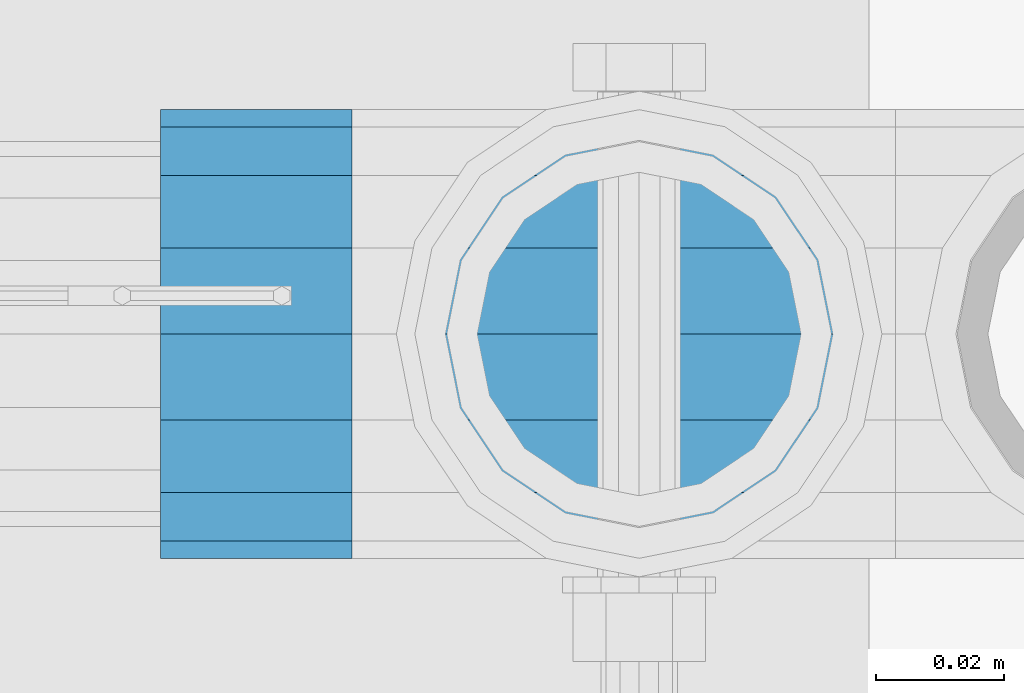
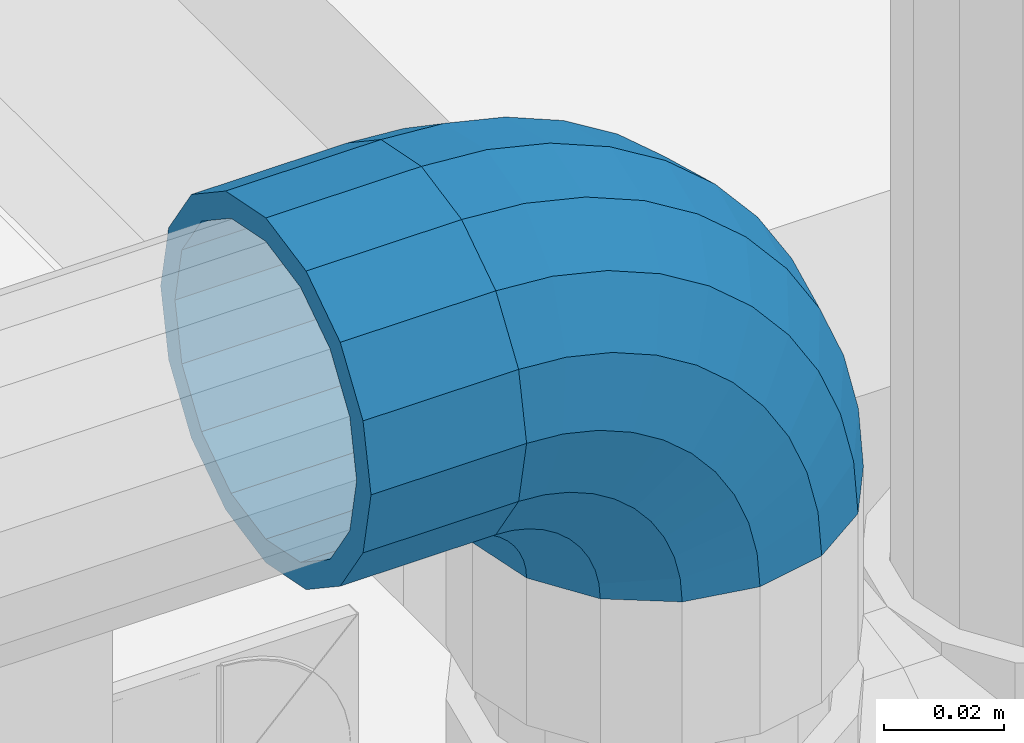
# One storey, part 141 of 208: 1 beam, 1 member.
"""IFC2X3 building model written with IfcOpenShell, lengths in millimetres."""

from ifc_helpers import new_model, si_unit, frame, origin_with_axes, place, context, subcontext, project, spatial, faceted_brep, material, type_object, element, save


model = new_model("IFC2X3")

# Units and contexts
model_context = context("Model", 3, precision=1e-05, world=origin_with_axes())
body_context = subcontext(model_context, "Body", "Model", "MODEL_VIEW")
ifc_project = project(units=[si_unit("LENGTHUNIT", "METRE", prefix="MILLI"), si_unit("AREAUNIT", "SQUARE_METRE"), si_unit("VOLUMEUNIT", "CUBIC_METRE"), si_unit("MASSUNIT", "GRAM", prefix="KILO"), si_unit("TIMEUNIT", "SECOND"), si_unit("PLANEANGLEUNIT", "RADIAN"), si_unit("SOLIDANGLEUNIT", "STERADIAN"), si_unit("THERMODYNAMICTEMPERATUREUNIT", "DEGREE_CELSIUS"), si_unit("LUMINOUSINTENSITYUNIT", "LUMEN")], contexts=[model_context])

# Site, building, storey
site_placement = place(None, origin_with_axes())
site = spatial("IfcSite", under=ifc_project, at=site_placement, CompositionType="ELEMENT")
building_placement = place(site_placement, origin_with_axes())
building = spatial("IfcBuilding", under=site, at=building_placement, Name="Standard", CompositionType="ELEMENT")
storey_placement = place(building_placement, origin_with_axes())
storey = spatial("IfcBuildingStorey", under=building, at=storey_placement, Name="Undefined", CompositionType="ELEMENT", Elevation=0.0)

# Beam
ifc_material = material(Name="Misc_Undefined")
beam_type = type_object("IfcBeamType", PredefinedType="NOTDEFINED")
beam_placement = place(storey_placement, frame((-26274.0, 4664.5, 969.85), z_axis=(0.0, 0.0, 1.0), x_axis=(-1.0, 0.0, 0.0)))
element("IfcBeam", 1, at=beam_placement, inside=storey, type_object=beam_type, material=ifc_material, context=body_context, shape_type="Brep", body=[
    faceted_brep([(0.0, -30.3500000000004, 0.0), (0.0, -28.0397438117179, 11.6144421722784), (30.0, -28.0397438117179, 11.6144421722805), (30.0, -30.3500000000004, 0.0), (0.0, -21.4606908090118, 21.4606908090136), (30.0, -21.4606908090118, 21.4606908090117), (0.0, -11.6144421722802, 28.0397438117143), (30.0, -11.6144421722802, 28.0397438117175), (0.0, 0.0, 30.3499999999985), (30.0, 0.0, 30.35), (0.0, 11.6144421722802, 28.0397438117143), (30.0, 11.6144421722802, 28.0397438117175), (0.0, 21.4606908090118, 21.4606908090136), (30.0, 21.4606908090118, 21.4606908090117), (0.0, 28.0397438117179, 11.6144421722784), (30.0, 28.0397438117179, 11.6144421722805), (0.0, 30.3500000000004, 0.0), (30.0, 30.3500000000004, 0.0), (0.0, 28.0397438117179, -11.6144421722784), (30.0, 28.0397438117179, -11.6144421722805), (0.0, 21.4606908090118, -21.4606908090136), (30.0, 21.4606908090118, -21.4606908090117), (0.0, 11.6144421722802, -28.0397438117143), (30.0, 11.6144421722802, -28.0397438117175), (0.0, 0.0, -30.3499999999985), (30.0, 0.0, -30.35), (0.0, -11.6144421722802, -28.0397438117143), (30.0, -11.6144421722802, -28.0397438117175), (0.0, -21.4606908090118, -21.4606908090136), (30.0, -21.4606908090118, -21.4606908090117), (0.0, -28.0397438117179, -11.6144421722784), (30.0, -28.0397438117179, -11.6144421722805), (0.0, -35.1499999999996, 0.0), (0.0, -32.4743655677721, -13.4513226476338), (30.0, -32.4743655677721, -13.4513226476329), (30.0, -35.1499999999996, 0.0), (0.0, -24.8548033587067, -24.8548033587067), (30.0, -24.8548033587067, -24.8548033587072), (0.0, -13.4513226476329, -32.4743655677739), (30.0, -13.4513226476329, -32.4743655677717), (0.0, 0.0, -35.1499999999996), (30.0, 0.0, -35.15), (0.0, 13.4513226476329, -32.4743655677739), (30.0, 13.4513226476329, -32.4743655677717), (0.0, 24.8548033587067, -24.8548033587067), (30.0, 24.8548033587067, -24.8548033587072), (0.0, 32.4743655677721, -13.4513226476338), (30.0, 32.4743655677721, -13.4513226476329), (0.0, 35.1499999999996, 0.0), (30.0, 35.1499999999996, 0.0), (0.0, 32.4743655677721, 13.4513226476338), (30.0, 32.4743655677721, 13.4513226476329), (0.0, 24.8548033587067, 24.8548033587067), (30.0, 24.8548033587067, 24.8548033587072), (0.0, 13.4513226476329, 32.4743655677739), (30.0, 13.4513226476329, 32.4743655677717), (0.0, 0.0, 35.1499999999996), (30.0, 0.0, 35.15), (0.0, -13.4513226476329, 32.4743655677739), (30.0, -13.4513226476329, 32.4743655677717), (0.0, -24.8548033587067, 24.8548033587067), (30.0, -24.8548033587067, 24.8548033587072), (0.0, -32.4743655677721, 13.4513226476338), (30.0, -32.4743655677721, 13.4513226476329)], [[[0, 1, 2, 3]], [[1, 4, 5, 2]], [[4, 6, 7, 5]], [[6, 8, 9, 7]], [[8, 10, 11, 9]], [[10, 12, 13, 11]], [[12, 14, 15, 13]], [[14, 16, 17, 15]], [[16, 18, 19, 17]], [[18, 20, 21, 19]], [[20, 22, 23, 21]], [[22, 24, 25, 23]], [[24, 26, 27, 25]], [[26, 28, 29, 27]], [[28, 30, 31, 29]], [[30, 0, 3, 31]], [[32, 33, 34, 35]], [[33, 36, 37, 34]], [[36, 38, 39, 37]], [[38, 40, 41, 39]], [[40, 42, 43, 41]], [[42, 44, 45, 43]], [[44, 46, 47, 45]], [[46, 48, 49, 47]], [[48, 50, 51, 49]], [[50, 52, 53, 51]], [[52, 54, 55, 53]], [[54, 56, 57, 55]], [[56, 58, 59, 57]], [[58, 60, 61, 59]], [[60, 62, 63, 61]], [[62, 32, 35, 63]], [[37, 39, 41, 43, 45, 47, 49, 51, 53, 55, 57, 59, 61, 63, 35, 34], [5, 7, 9, 11, 13, 15, 17, 19, 21, 23, 25, 27, 29, 31, 3, 2]], [[62, 60, 58, 56, 54, 52, 50, 48, 46, 44, 42, 40, 38, 36, 33, 32], [30, 28, 26, 24, 22, 20, 18, 16, 14, 12, 10, 8, 6, 4, 1, 0]]]),
])

# Member
member_type = type_object("IfcMemberType", PredefinedType="NOTDEFINED")
member_placement = place(storey_placement, frame((-26229.0, 4664.5, 924.85), z_axis=(0.707106781186539, -1.49999999888231e-07, 0.70710678118654), x_axis=(-0.707106781186548, 0.0, 0.707106781186548)))
element("IfcMember", 2, at=member_placement, inside=storey, type_object=member_type, material=ifc_material, context=body_context, shape_type="Brep", body=[
    faceted_brep([(0.0, -35.1499999999996, 0.0), (9.51152146007371, -32.4743655677721, -9.51152146006643), (13.2759578763435, -32.4743655677721, -6.29638902527222), (5.3694688002397, -35.1499999999996, 4.58595959348168), (17.5750000000044, -24.8548033587067, -17.5749999999971), (19.9787556631163, -24.8548033587067, -15.5219987155615), (22.9628441077075, -13.4513226476329, -22.9628441076966), (24.4574219585302, -13.4513226476329, -21.6863540323902), (24.854803358714, 0.0, -24.8548033587031), (26.0301204183197, 0.0, -23.8509877588003), (22.9628441077075, 13.4513226476329, -22.9628441076966), (24.4574219585302, 13.4513226476329, -21.6863540323902), (17.5750000000044, 24.8548033587067, -17.5749999999971), (19.9787556631163, 24.8548033587067, -15.5219987155615), (9.51152146007371, 32.4743655677721, -9.51152146006643), (13.2759578763435, 32.4743655677721, -6.29638902527222), (0.0, 35.1499999999996, 0.0), (5.3694688002397, 35.1499999999996, 4.58595959348168), (-9.51152146006643, 32.4743655677721, 9.51152146007371), (-2.53702027587133, 32.4743655677721, 15.4683082122356), (-17.5749999999935, 24.8548033587067, 17.5750000000044), (-9.23981806264055, 24.8548033587067, 24.6939179025248), (-22.9628441076966, 13.4513226476329, 22.9628441077039), (-13.7184843580508, 13.4513226476329, 30.8582732193536), (-24.8548033587031, 0.0, 24.854803358714), (-15.2911828178439, 0.0, 33.02290694576), (-22.9628441076966, -13.4513226476329, 22.9628441077039), (-13.7184843580508, -13.4513226476329, 30.8582732193536), (-17.5749999999935, -24.8548033587067, 17.5750000000044), (-9.23981806264055, -24.8548033587067, 24.6939179025248), (-9.51152146006643, -32.4743655677721, 9.51152146007371), (-2.53702027587133, -32.4743655677721, 15.4683082122356), (0.0, -30.3500000000004, 0.0), (-8.21265081971433, -28.0397438117179, 8.21265081972524), (-1.45732902223244, -28.0397438117179, 13.9822406910389), (5.3694688002397, -30.3500000000004, 4.58595959348168), (-15.1749999999956, -21.4606908090118, 15.1750000000029), (-7.24480876130838, -21.4606908090118, 21.9480231689995), (-19.8270929919963, -11.6144421722802, 19.8270929920036), (-11.1118790903529, -11.6144421722802, 27.2705888550809), (-21.4606908090063, 0.0, 21.4606908090136), (-12.46981360684, 0.0, 29.139625372758), (-19.8270929919963, 11.6144421722802, 19.8270929920036), (-11.1118790903529, 11.6144421722802, 27.2705888550809), (-15.1749999999956, 21.4606908090118, 15.1750000000029), (-7.24480876130838, 21.4606908090118, 21.9480231689995), (-8.21265081971433, 28.0397438117179, 8.21265081972524), (-1.45732902223244, 28.0397438117179, 13.9822406910389), (0.0, 30.3500000000004, 0.0), (5.3694688002397, 30.3500000000004, 4.58595959348168), (8.21265081972524, 28.0397438117179, -8.21265081971433), (12.1962666227082, 28.0397438117179, -4.81032150407918), (15.1750000000029, 21.4606908090118, -15.1749999999956), (17.9837463617841, 21.4606908090118, -12.7761039820325), (19.8270929920036, 11.6144421722802, -19.8270929919963), (21.850816690825, 11.6144421722802, -18.0986696681175), (21.4606908090136, 0.0, -21.4606908090063), (23.2087512073158, 0.0, -19.9677061857983), (19.8270929920036, -11.6144421722802, -19.8270929919963), (21.850816690825, -11.6144421722802, -18.0986696681175), (15.1750000000029, -21.4606908090118, -15.1749999999956), (17.9837463617841, -21.4606908090118, -12.7761039820325), (8.21265081972524, -28.0397438117179, -8.21265081971433), (12.1962666227082, -28.0397438117179, -4.81032150407918), (17.4970053560755, -32.4743655677721, -3.70972780291777), (11.3902326651187, -35.1499999999996, 8.27548843508339), (22.6740772628655, -24.8548033587067, -13.870303514941), (26.1332861179544, -13.4513226476329, -20.6593831546779), (27.3479987309656, 0.0, -23.0433908901359), (26.1332861179544, 13.4513226476329, -20.6593831546779), (22.6740772628655, 24.8548033587067, -13.870303514941), (17.4970053560755, 32.4743655677721, -3.70972780291777), (11.3902326651187, 35.1499999999996, 8.27548843508339), (5.28345997416181, 32.4743655677721, 20.2607046730918), (0.106388067368243, 24.8548033587067, 30.4212803851115), (-3.3528207877207, 13.4513226476329, 37.2103600248483), (-4.56753340072828, 0.0, 39.59436776031), (-3.3528207877207, -13.4513226476329, 37.2103600248483), (0.106388067368243, -24.8548033587067, 30.4212803851115), (5.28345997416181, -32.4743655677721, 20.2607046730918), (6.11738625912767, -28.0397438117179, 18.6240321853948), (11.3902326651187, -30.3500000000004, 8.27548843508339), (1.64728291998108, -21.4606908090118, 27.3971039595053), (-1.33954464053022, -11.6144421722802, 33.2590831078996), (-2.38837900197541, 0.0, 35.3175364441995), (-1.33954464053022, 11.6144421722802, 33.2590831078996), (1.64728291998108, 21.4606908090118, 27.3971039595053), (6.11738625912767, 28.0397438117179, 18.6240321853948), (11.3902326651187, 30.3500000000004, 8.27548843508339), (16.663079071106, 28.0397438117179, -2.07305531522434), (21.1331824102563, 21.4606908090118, -10.8461270893349), (24.1200099707712, 11.6144421722802, -16.7081062377256), (25.1688443322128, 0.0, -18.7665595740327), (24.1200099707712, -11.6144421722802, -16.7081062377256), (21.1331824102563, -21.4606908090118, -10.8461270893349), (16.663079071106, -28.0397438117179, -2.07305531522434), (22.0707277014626, -32.4743655677721, -1.81522997692809), (17.9140404065256, -35.1499999999996, 10.9777380798914), (25.5945970362154, -24.8548033587067, -12.6605846156417), (27.9491712485142, -13.4513226476329, -19.9072189058897), (28.7759877588032, 0.0, -22.4518984678834), (27.9491712485142, 13.4513226476329, -19.9072189058897), (25.5945970362154, 24.8548033587067, -12.6605846156417), (22.0707277014626, 32.4743655677721, -1.81522997692809), (17.9140404065256, 35.1499999999996, 10.9777380798914), (13.7573531115886, 32.4743655677721, 23.7707061367109), (10.2334837768358, 24.8548033587067, 34.6160607754246), (7.87890956454066, 13.4513226476329, 41.8626950656726), (7.05209305424796, 0.0, 44.4073746276663), (7.87890956454066, -13.4513226476329, 41.8626950656726), (10.2334837768358, -24.8548033587067, 34.6160607754246), (13.7573531115886, -32.4743655677721, 23.7707061367109), (14.3249803951076, -28.0397438117179, 22.023728990971), (17.9140404065256, -30.3500000000004, 10.9777380798914), (11.2823222355146, -21.4606908090118, 31.3880679180002), (9.2492830507872, -11.6144421722802, 37.6451191472734), (8.53537462724489, 0.0, 39.8423033494473), (9.2492830507872, 11.6144421722802, 37.6451191472734), (11.2823222355146, 21.4606908090118, 31.3880679180002), (14.3249803951076, 28.0397438117179, 22.023728990971), (17.9140404065256, 30.3500000000004, 10.9777380798914), (21.5031004179436, 28.0397438117179, -0.0682528311917849), (24.5457585775366, 21.4606908090118, -9.43259175821368), (26.5787977622676, 11.6144421722802, -15.6896429874905), (27.2927061858063, 0.0, -17.8868271896645), (26.5787977622676, -11.6144421722802, -15.6896429874905), (24.5457585775366, -21.4606908090118, -9.43259175821368), (21.5031004179436, -28.0397438117179, -0.0682528311917849), (26.8845046890528, -32.4743655677721, -0.659544371261291), (24.7802542265854, -35.1499999999996, 12.6261701733893), (28.6684020936882, -24.8548033587067, -11.9226293117899), (29.860364231703, -13.4513226476329, -19.4483820661189), (30.2789256727519, 0.0, -22.0910749985305), (29.860364231703, 13.4513226476329, -19.4483820661189), (28.6684020936882, 24.8548033587067, -11.9226293117899), (26.8845046890528, 32.4743655677721, -0.659544371261291), (24.7802542265854, 35.1499999999996, 12.6261701733893), (22.6760037641179, 32.4743655677721, 25.9118847180434), (20.8921063594898, 24.8548033587067, 37.1749696585721), (19.7001442214714, 13.4513226476329, 44.7007224129011), (19.2815827804225, 0.0, 47.343415345309), (19.7001442214714, -13.4513226476329, 44.7007224129011), (20.8921063594898, -24.8548033587067, 37.1749696585721), (22.6760037641179, -32.4743655677721, 25.9118847180434), (22.9633551786246, -28.0397438117179, 24.0976192894668), (24.7802542265854, -30.3500000000004, 12.6261701733893), (21.4230625404853, -21.4606908090118, 33.8226442665691), (20.3938719035395, -11.6144421722802, 40.3206982094998), (20.0324682126193, 0.0, 42.6025113104552), (20.3938719035395, 11.6144421722802, 40.3206982094998), (21.4230625404853, 21.4606908090118, 33.8226442665691), (22.9633551786246, 28.0397438117179, 24.0976192894668), (24.7802542265854, 30.3500000000004, 12.6261701733893), (26.5971532745498, 28.0397438117179, 1.15472105731169), (28.1374459126891, 21.4606908090118, -8.5703039197906), (29.1666365496385, 11.6144421722802, -15.0683578627177), (29.5280402405588, 0.0, -17.350170963673), (29.1666365496385, -11.6144421722802, -15.0683578627177), (28.1374459126891, -21.4606908090118, -8.5703039197906), (26.5971532745498, -28.0397438117179, 1.15472105731169), (31.8198051533982, -32.4743655677721, -0.271127801024704), (31.8198051533982, -35.1499999999996, 13.1801948466091), (31.8198051533982, -24.8548033587067, -11.6746085120976), (31.8198051533982, -13.4513226476329, -19.2941707211648), (31.8198051533982, 0.0, -21.9698051533924), (31.8198051533982, 13.4513226476329, -19.2941707211648), (31.8198051533982, 24.8548033587067, -11.6746085120976), (31.8198051533982, 32.4743655677721, -0.271127801024704), (31.8198051533982, 35.1499999999996, 13.1801948466091), (31.8198051533982, 32.4743655677721, 26.6315174942429), (31.8198051533982, 24.8548033587067, 38.0349982053158), (31.8198051533946, 13.4513226476329, 45.654560414383), (31.8198051534018, 0.0, 48.3301948466105), (31.8198051533946, -13.4513226476329, 45.654560414383), (31.8198051533982, -24.8548033587067, 38.0349982053158), (31.8198051533982, -32.4743655677721, 26.6315174942429), (31.8198051533982, -28.0397438117179, 24.7946370188874), (31.8198051533982, -30.3500000000004, 13.1801948466091), (31.8198051533982, -21.4606908090118, 34.6408856556227), (31.8198051533982, -11.6144421722802, 41.219938658327), (31.8198051533982, 0.0, 43.5301948466113), (31.8198051533982, 11.6144421722802, 41.219938658327), (31.8198051533982, 21.4606908090118, 34.6408856556227), (31.8198051533982, 28.0397438117179, 24.7946370188874), (31.8198051533982, 30.3500000000004, 13.1801948466091), (31.8198051533946, 28.0397438117179, 1.56575267433072), (31.8198051533982, 21.4606908090118, -8.28049596240453), (31.8198051533982, 11.6144421722802, -14.8595489651088), (31.8198051533982, 0.0, -17.1698051533895), (31.8198051533982, -11.6144421722802, -14.8595489651088), (31.8198051533982, -21.4606908090118, -8.28049596240453), (31.8198051533946, -28.0397438117179, 1.56575267433072), (36.7551056177435, -32.4743655677721, -0.659544371261291), (38.859356080211, -35.1499999999996, 12.6261701733929), (34.9712082131082, -24.8548033587067, -11.9226293117899), (33.7792460750898, -13.4513226476329, -19.4483820661189), (33.3606846340444, 0.0, -22.0910749985269), (33.7792460750898, 13.4513226476329, -19.4483820661189), (34.9712082131082, 24.8548033587067, -11.9226293117899), (36.7551056177435, 32.4743655677721, -0.659544371261291), (38.859356080211, 35.1499999999996, 12.6261701733929), (40.9636065426712, 32.4743655677721, 25.9118847180434), (42.7475039473065, 24.8548033587067, 37.1749696585684), (43.939466085325, 13.4513226476329, 44.7007224129047), (44.3580275263703, 0.0, 47.343415345309), (43.939466085325, -13.4513226476329, 44.7007224129047), (42.7475039473065, -24.8548033587067, 37.1749696585684), (40.9636065426712, -32.4743655677721, 25.9118847180434), (40.6762551281718, -28.0397438117179, 24.0976192894668), (38.859356080211, -30.3500000000004, 12.6261701733929), (42.2165477663111, -21.4606908090118, 33.8226442665691), (43.2457384032568, -11.6144421722802, 40.3206982094998), (43.6071420941771, 0.0, 42.6025113104515), (43.2457384032568, 11.6144421722802, 40.3206982094998), (42.2165477663111, 21.4606908090118, 33.8226442665691), (40.6762551281718, 28.0397438117179, 24.0976192894668), (38.859356080211, 30.3500000000004, 12.6261701733929), (37.0424570322466, 28.0397438117179, 1.15472105731169), (35.5021643941072, 21.4606908090118, -8.5703039197906), (34.4729737571579, 11.6144421722802, -15.0683578627177), (34.1115700662376, 0.0, -17.350170963673), (34.4729737571579, -11.6144421722802, -15.0683578627177), (35.5021643941072, -21.4606908090118, -8.5703039197906), (37.0424570322466, -28.0397438117179, 1.15472105731169), (41.5688826053338, -32.4743655677721, -1.81522997692809), (45.7255699002708, -35.1499999999996, 10.9777380798914), (38.045013270581, -24.8548033587067, -12.6605846156417), (35.6904390582822, -13.4513226476329, -19.9072189058897), (34.8636225479895, 0.0, -22.4518984678834), (35.6904390582822, 13.4513226476329, -19.9072189058897), (38.045013270581, 24.8548033587067, -12.6605846156417), (41.5688826053338, 32.4743655677721, -1.81522997692809), (45.7255699002708, 35.1499999999996, 10.9777380798914), (49.8822571952114, 32.4743655677721, 23.7707061367109), (53.4061265299606, 24.8548033587067, 34.6160607754246), (55.7607007422557, 13.4513226476329, 41.8626950656726), (56.5875172525484, 0.0, 44.4073746276699), (55.7607007422557, -13.4513226476329, 41.8626950656726), (53.4061265299606, -24.8548033587067, 34.6160607754246), (49.8822571952114, -32.4743655677721, 23.7707061367109), (49.3146299116925, -28.0397438117179, 22.0237289909746), (45.7255699002708, -30.3500000000004, 10.9777380798914), (52.3572880712818, -21.4606908090118, 31.3880679179965), (54.3903272560092, -11.6144421722802, 37.6451191472697), (55.1042356795515, 0.0, 39.8423033494473), (54.3903272560092, 11.6144421722802, 37.6451191472697), (52.3572880712818, 21.4606908090118, 31.3880679179965), (49.3146299116925, 28.0397438117179, 22.0237289909746), (45.7255699002708, 30.3500000000004, 10.9777380798914), (42.1365098888527, 28.0397438117179, -0.0682528311917849), (39.0938517292598, 21.4606908090118, -9.43259175821368), (37.0608125445287, 11.6144421722802, -15.6896429874905), (36.3469041209937, 0.0, -17.8868271896645), (37.0608125445287, -11.6144421722802, -15.6896429874905), (39.0938517292598, -21.4606908090118, -9.43259175821368), (42.1365098888527, -28.0397438117179, -0.0682528311917849), (46.1426049507245, -32.4743655677721, -3.70972780291777), (52.2493776416777, -35.1499999999996, 8.27548843508339), (40.9655330439309, -24.8548033587067, -13.870303514941), (37.506324188842, -13.4513226476329, -20.6593831546743), (36.2916115758308, 0.0, -23.0433908901359), (37.506324188842, 13.4513226476329, -20.6593831546743), (40.9655330439309, 24.8548033587067, -13.870303514941), (46.1426049507245, 32.4743655677721, -3.70972780291777), (52.2493776416777, 35.1499999999996, 8.27548843508339), (58.3561503326309, 32.4743655677721, 20.2607046730918), (63.5332222394245, 24.8548033587067, 30.4212803851151), (66.9924310945171, 13.4513226476329, 37.2103600248483), (68.207143707521, 0.0, 39.5943677603063), (66.9924310945171, -13.4513226476329, 37.2103600248483), (63.5332222394245, -24.8548033587067, 30.4212803851151), (58.3561503326309, -32.4743655677721, 20.2607046730918), (57.5222240476687, -28.0397438117179, 18.6240321853984), (52.2493776416777, -30.3500000000004, 8.27548843508339), (61.9923273868153, -21.4606908090118, 27.3971039595053), (64.9791549473266, -11.6144421722802, 33.259083107896), (66.0279893087718, 0.0, 35.3175364442068), (64.9791549473266, 11.6144421722802, 33.259083107896), (61.9923273868153, 21.4606908090118, 27.3971039595053), (57.5222240476687, 28.0397438117179, 18.6240321853984), (52.2493776416777, 30.3500000000004, 8.27548843508339), (46.9765312356867, 28.0397438117179, -2.0730553152207), (42.5064278965401, 21.4606908090118, -10.8461270893349), (39.5196003360288, 11.6144421722802, -16.7081062377256), (38.4707659745836, 0.0, -18.7665595740327), (39.5196003360288, -11.6144421722802, -16.7081062377256), (42.5064278965401, -21.4606908090118, -10.8461270893349), (46.9765312356867, -28.0397438117179, -2.0730553152207), (50.3636524304529, -32.4743655677721, -6.29638902527222), (58.2701415065603, -35.1499999999996, 4.58595959348168), (43.6608546436801, -24.8548033587067, -15.5219987155615), (39.1821883482698, -13.4513226476329, -21.6863540323902), (37.6094898884767, 0.0, -23.8509877587967), (39.1821883482698, 13.4513226476329, -21.6863540323902), (43.6608546436801, 24.8548033587067, -15.5219987155615), (50.3636524304529, 32.4743655677721, -6.29638902527222), (58.2701415065603, 35.1499999999996, 4.58595959348168), (66.1766305826677, 32.4743655677721, 15.4683082122392), (72.8794283694369, 24.8548033587067, 24.6939179025212), (77.3580946648508, 13.4513226476329, 30.8582732193536), (78.9307931246403, 0.0, 33.02290694576), (77.3580946648508, -13.4513226476329, 30.8582732193536), (72.8794283694369, -24.8548033587067, 24.6939179025212), (66.1766305826677, -32.4743655677721, 15.4683082122392), (65.0969393290288, -28.0397438117179, 13.9822406910425), (58.2701415065603, -30.3500000000004, 4.58595959348168), (70.8844190681048, -21.4606908090118, 21.9480231689995), (74.7514893971456, -11.6144421722802, 27.2705888550845), (76.1094239136364, 0.0, 29.1396253727617), (74.7514893971456, 11.6144421722802, 27.2705888550845), (70.8844190681048, 21.4606908090118, 21.9480231689995), (65.0969393290288, 28.0397438117179, 13.9822406910425), (58.2701415065603, 30.3500000000004, 4.58595959348168), (51.4433436840882, 28.0397438117179, -4.81032150407918), (45.6558639450122, 21.4606908090118, -12.7761039820361), (41.7887936159714, 11.6144421722802, -18.0986696681175), (40.4308590994842, 0.0, -19.9677061857983), (41.7887936159714, -11.6144421722802, -18.0986696681175), (45.6558639450122, -21.4606908090118, -12.7761039820361), (51.4433436840882, -28.0397438117179, -4.81032150407918), (54.1280888467227, -32.4743655677721, -9.51152146006643), (63.6396103067927, -35.1499999999996, 3.63797880709171e-12), (46.064610306792, -24.8548033587067, -17.5749999999971), (40.6767661990889, -13.4513226476329, -22.9628441077002), (38.784806948086, 0.0, -24.8548033587031), (40.6767661990889, 13.4513226476329, -22.9628441077002), (46.064610306792, 24.8548033587067, -17.5749999999971), (54.1280888467227, 32.4743655677721, -9.51152146006643), (63.6396103067927, 35.1499999999996, 3.63797880709171e-12), (73.1511317668628, 32.4743655677721, 9.51152146007371), (81.2146103067935, 24.8548033587067, 17.5750000000044), (86.602454414493, 13.4513226476329, 22.9628441077075), (88.4944136654995, 0.0, 24.8548033587103), (86.602454414493, -13.4513226476329, 22.9628441077075), (81.2146103067935, -24.8548033587067, 17.5750000000044), (73.1511317668628, -32.4743655677721, 9.51152146007371), (71.8522611265107, -28.0397438117179, 8.2126508197216), (63.6396103067927, -30.3500000000004, 3.63797880709171e-12), (78.814610306792, -21.4606908090118, 15.1750000000029), (83.4667032987927, -11.6144421722802, 19.8270929920036), (85.1003011158027, 0.0, 21.4606908090136), (83.4667032987927, 11.6144421722802, 19.8270929920036), (78.814610306792, 21.4606908090118, 15.1750000000029), (71.8522611265107, 28.0397438117179, 8.2126508197216), (63.6396103067927, 30.3500000000004, 3.63797880709171e-12), (55.4269594870748, 28.0397438117179, -8.21265081971433), (48.4646103067935, 21.4606908090118, -15.1749999999956), (43.8125173147928, 11.6144421722802, -19.8270929919963), (42.1789194977791, 0.0, -21.4606908090063), (43.8125173147928, -11.6144421722802, -19.8270929919963), (48.4646103067935, -21.4606908090118, -15.1749999999956), (55.4269594870748, -28.0397438117179, -8.21265081971433)], [[[0, 1, 2, 3]], [[1, 4, 5, 2]], [[4, 6, 7, 5]], [[6, 8, 9, 7]], [[8, 10, 11, 9]], [[10, 12, 13, 11]], [[12, 14, 15, 13]], [[14, 16, 17, 15]], [[16, 18, 19, 17]], [[18, 20, 21, 19]], [[20, 22, 23, 21]], [[22, 24, 25, 23]], [[24, 26, 27, 25]], [[26, 28, 29, 27]], [[28, 30, 31, 29]], [[30, 0, 3, 31]], [[32, 33, 34, 35]], [[33, 36, 37, 34]], [[36, 38, 39, 37]], [[38, 40, 41, 39]], [[40, 42, 43, 41]], [[42, 44, 45, 43]], [[44, 46, 47, 45]], [[46, 48, 49, 47]], [[48, 50, 51, 49]], [[50, 52, 53, 51]], [[52, 54, 55, 53]], [[54, 56, 57, 55]], [[56, 58, 59, 57]], [[58, 60, 61, 59]], [[60, 62, 63, 61]], [[62, 32, 35, 63]], [[30, 28, 26, 24, 22, 20, 18, 16, 14, 12, 10, 8, 6, 4, 1, 0], [62, 60, 58, 56, 54, 52, 50, 48, 46, 44, 42, 40, 38, 36, 33, 32]], [[3, 2, 64, 65]], [[2, 5, 66, 64]], [[5, 7, 67, 66]], [[7, 9, 68, 67]], [[9, 11, 69, 68]], [[11, 13, 70, 69]], [[13, 15, 71, 70]], [[15, 17, 72, 71]], [[17, 19, 73, 72]], [[19, 21, 74, 73]], [[21, 23, 75, 74]], [[23, 25, 76, 75]], [[25, 27, 77, 76]], [[27, 29, 78, 77]], [[29, 31, 79, 78]], [[31, 3, 65, 79]], [[35, 34, 80, 81]], [[34, 37, 82, 80]], [[37, 39, 83, 82]], [[39, 41, 84, 83]], [[41, 43, 85, 84]], [[43, 45, 86, 85]], [[45, 47, 87, 86]], [[47, 49, 88, 87]], [[49, 51, 89, 88]], [[51, 53, 90, 89]], [[53, 55, 91, 90]], [[55, 57, 92, 91]], [[57, 59, 93, 92]], [[59, 61, 94, 93]], [[61, 63, 95, 94]], [[63, 35, 81, 95]], [[65, 64, 96, 97]], [[64, 66, 98, 96]], [[66, 67, 99, 98]], [[67, 68, 100, 99]], [[68, 69, 101, 100]], [[69, 70, 102, 101]], [[70, 71, 103, 102]], [[71, 72, 104, 103]], [[72, 73, 105, 104]], [[73, 74, 106, 105]], [[74, 75, 107, 106]], [[75, 76, 108, 107]], [[76, 77, 109, 108]], [[77, 78, 110, 109]], [[78, 79, 111, 110]], [[79, 65, 97, 111]], [[81, 80, 112, 113]], [[80, 82, 114, 112]], [[82, 83, 115, 114]], [[83, 84, 116, 115]], [[84, 85, 117, 116]], [[85, 86, 118, 117]], [[86, 87, 119, 118]], [[87, 88, 120, 119]], [[88, 89, 121, 120]], [[89, 90, 122, 121]], [[90, 91, 123, 122]], [[91, 92, 124, 123]], [[92, 93, 125, 124]], [[93, 94, 126, 125]], [[94, 95, 127, 126]], [[95, 81, 113, 127]], [[97, 96, 128, 129]], [[96, 98, 130, 128]], [[98, 99, 131, 130]], [[99, 100, 132, 131]], [[100, 101, 133, 132]], [[101, 102, 134, 133]], [[102, 103, 135, 134]], [[103, 104, 136, 135]], [[104, 105, 137, 136]], [[105, 106, 138, 137]], [[106, 107, 139, 138]], [[107, 108, 140, 139]], [[108, 109, 141, 140]], [[109, 110, 142, 141]], [[110, 111, 143, 142]], [[111, 97, 129, 143]], [[113, 112, 144, 145]], [[112, 114, 146, 144]], [[114, 115, 147, 146]], [[115, 116, 148, 147]], [[116, 117, 149, 148]], [[117, 118, 150, 149]], [[118, 119, 151, 150]], [[119, 120, 152, 151]], [[120, 121, 153, 152]], [[121, 122, 154, 153]], [[122, 123, 155, 154]], [[123, 124, 156, 155]], [[124, 125, 157, 156]], [[125, 126, 158, 157]], [[126, 127, 159, 158]], [[127, 113, 145, 159]], [[129, 128, 160, 161]], [[128, 130, 162, 160]], [[130, 131, 163, 162]], [[131, 132, 164, 163]], [[132, 133, 165, 164]], [[133, 134, 166, 165]], [[134, 135, 167, 166]], [[135, 136, 168, 167]], [[136, 137, 169, 168]], [[137, 138, 170, 169]], [[138, 139, 171, 170]], [[139, 140, 172, 171]], [[140, 141, 173, 172]], [[141, 142, 174, 173]], [[142, 143, 175, 174]], [[143, 129, 161, 175]], [[145, 144, 176, 177]], [[144, 146, 178, 176]], [[146, 147, 179, 178]], [[147, 148, 180, 179]], [[148, 149, 181, 180]], [[149, 150, 182, 181]], [[150, 151, 183, 182]], [[151, 152, 184, 183]], [[152, 153, 185, 184]], [[153, 154, 186, 185]], [[154, 155, 187, 186]], [[155, 156, 188, 187]], [[156, 157, 189, 188]], [[157, 158, 190, 189]], [[158, 159, 191, 190]], [[159, 145, 177, 191]], [[161, 160, 192, 193]], [[160, 162, 194, 192]], [[162, 163, 195, 194]], [[163, 164, 196, 195]], [[164, 165, 197, 196]], [[165, 166, 198, 197]], [[166, 167, 199, 198]], [[167, 168, 200, 199]], [[168, 169, 201, 200]], [[169, 170, 202, 201]], [[170, 171, 203, 202]], [[171, 172, 204, 203]], [[172, 173, 205, 204]], [[173, 174, 206, 205]], [[174, 175, 207, 206]], [[175, 161, 193, 207]], [[177, 176, 208, 209]], [[176, 178, 210, 208]], [[178, 179, 211, 210]], [[179, 180, 212, 211]], [[180, 181, 213, 212]], [[181, 182, 214, 213]], [[182, 183, 215, 214]], [[183, 184, 216, 215]], [[184, 185, 217, 216]], [[185, 186, 218, 217]], [[186, 187, 219, 218]], [[187, 188, 220, 219]], [[188, 189, 221, 220]], [[189, 190, 222, 221]], [[190, 191, 223, 222]], [[191, 177, 209, 223]], [[193, 192, 224, 225]], [[192, 194, 226, 224]], [[194, 195, 227, 226]], [[195, 196, 228, 227]], [[196, 197, 229, 228]], [[197, 198, 230, 229]], [[198, 199, 231, 230]], [[199, 200, 232, 231]], [[200, 201, 233, 232]], [[201, 202, 234, 233]], [[202, 203, 235, 234]], [[203, 204, 236, 235]], [[204, 205, 237, 236]], [[205, 206, 238, 237]], [[206, 207, 239, 238]], [[207, 193, 225, 239]], [[209, 208, 240, 241]], [[208, 210, 242, 240]], [[210, 211, 243, 242]], [[211, 212, 244, 243]], [[212, 213, 245, 244]], [[213, 214, 246, 245]], [[214, 215, 247, 246]], [[215, 216, 248, 247]], [[216, 217, 249, 248]], [[217, 218, 250, 249]], [[218, 219, 251, 250]], [[219, 220, 252, 251]], [[220, 221, 253, 252]], [[221, 222, 254, 253]], [[222, 223, 255, 254]], [[223, 209, 241, 255]], [[225, 224, 256, 257]], [[224, 226, 258, 256]], [[226, 227, 259, 258]], [[227, 228, 260, 259]], [[228, 229, 261, 260]], [[229, 230, 262, 261]], [[230, 231, 263, 262]], [[231, 232, 264, 263]], [[232, 233, 265, 264]], [[233, 234, 266, 265]], [[234, 235, 267, 266]], [[235, 236, 268, 267]], [[236, 237, 269, 268]], [[237, 238, 270, 269]], [[238, 239, 271, 270]], [[239, 225, 257, 271]], [[241, 240, 272, 273]], [[240, 242, 274, 272]], [[242, 243, 275, 274]], [[243, 244, 276, 275]], [[244, 245, 277, 276]], [[245, 246, 278, 277]], [[246, 247, 279, 278]], [[247, 248, 280, 279]], [[248, 249, 281, 280]], [[249, 250, 282, 281]], [[250, 251, 283, 282]], [[251, 252, 284, 283]], [[252, 253, 285, 284]], [[253, 254, 286, 285]], [[254, 255, 287, 286]], [[255, 241, 273, 287]], [[257, 256, 288, 289]], [[256, 258, 290, 288]], [[258, 259, 291, 290]], [[259, 260, 292, 291]], [[260, 261, 293, 292]], [[261, 262, 294, 293]], [[262, 263, 295, 294]], [[263, 264, 296, 295]], [[264, 265, 297, 296]], [[265, 266, 298, 297]], [[266, 267, 299, 298]], [[267, 268, 300, 299]], [[268, 269, 301, 300]], [[269, 270, 302, 301]], [[270, 271, 303, 302]], [[271, 257, 289, 303]], [[273, 272, 304, 305]], [[272, 274, 306, 304]], [[274, 275, 307, 306]], [[275, 276, 308, 307]], [[276, 277, 309, 308]], [[277, 278, 310, 309]], [[278, 279, 311, 310]], [[279, 280, 312, 311]], [[280, 281, 313, 312]], [[281, 282, 314, 313]], [[282, 283, 315, 314]], [[283, 284, 316, 315]], [[284, 285, 317, 316]], [[285, 286, 318, 317]], [[286, 287, 319, 318]], [[287, 273, 305, 319]], [[289, 288, 320, 321]], [[288, 290, 322, 320]], [[290, 291, 323, 322]], [[291, 292, 324, 323]], [[292, 293, 325, 324]], [[293, 294, 326, 325]], [[294, 295, 327, 326]], [[295, 296, 328, 327]], [[296, 297, 329, 328]], [[297, 298, 330, 329]], [[298, 299, 331, 330]], [[299, 300, 332, 331]], [[300, 301, 333, 332]], [[301, 302, 334, 333]], [[302, 303, 335, 334]], [[303, 289, 321, 335]], [[305, 304, 336, 337]], [[304, 306, 338, 336]], [[306, 307, 339, 338]], [[307, 308, 340, 339]], [[308, 309, 341, 340]], [[309, 310, 342, 341]], [[310, 311, 343, 342]], [[311, 312, 344, 343]], [[312, 313, 345, 344]], [[313, 314, 346, 345]], [[314, 315, 347, 346]], [[315, 316, 348, 347]], [[316, 317, 349, 348]], [[317, 318, 350, 349]], [[318, 319, 351, 350]], [[319, 305, 337, 351]], [[322, 323, 324, 325, 326, 327, 328, 329, 330, 331, 332, 333, 334, 335, 321, 320], [338, 339, 340, 341, 342, 343, 344, 345, 346, 347, 348, 349, 350, 351, 337, 336]]]),
])

save(model, "model.ifc")
